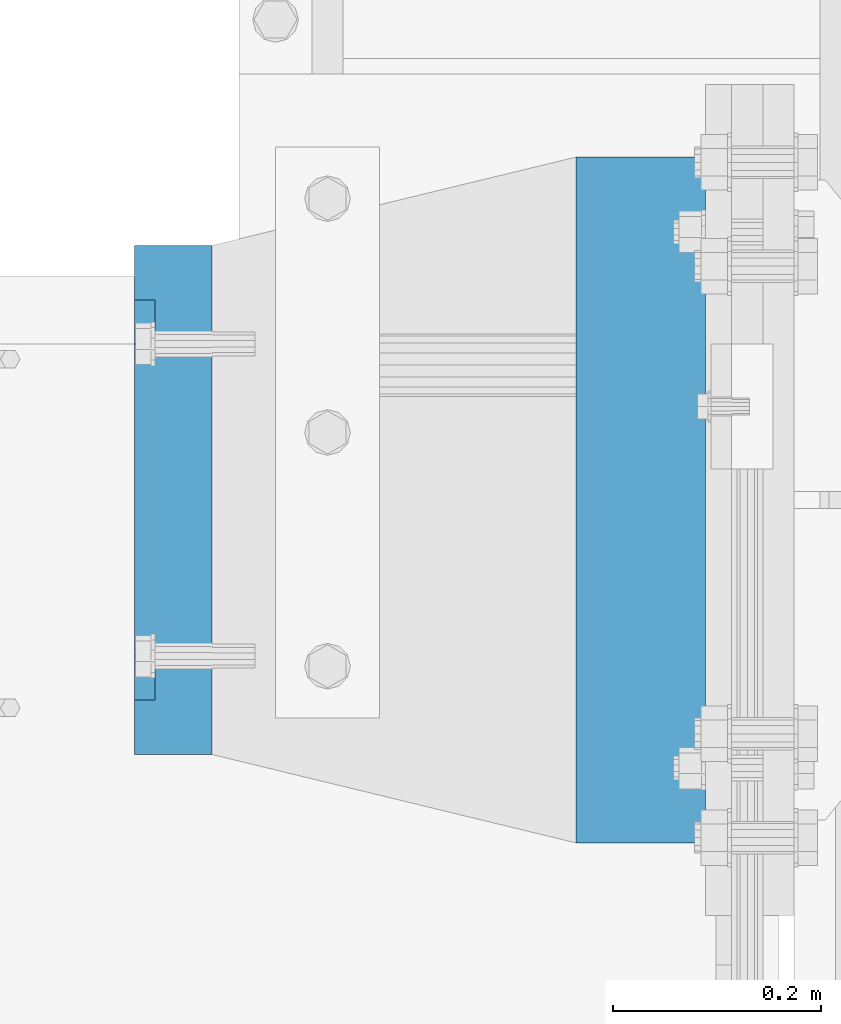
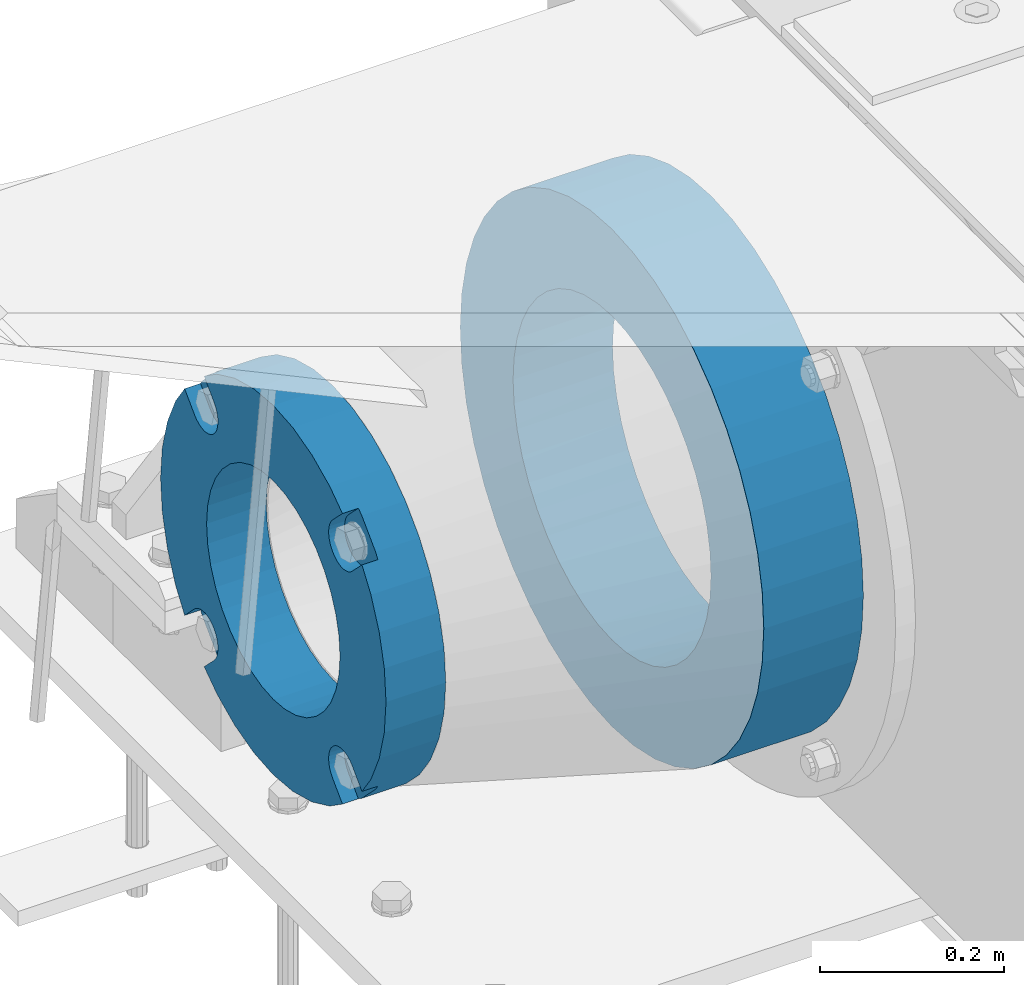
# One storey, part 145 of 242: 2 beams.
"""IFC2X3 building model written with IfcOpenShell, lengths in millimetres."""

from ifc_helpers import new_model, si_unit, frame, origin_with_axes, place, context, subcontext, project, spatial, faceted_brep, material, type_object, element, save


model = new_model("IFC2X3")

# Units and contexts
model_context = context("Model", 3, precision=1e-05, world=origin_with_axes())
body_context = subcontext(model_context, "Body", "Model", "MODEL_VIEW")
ifc_project = project(units=[si_unit("LENGTHUNIT", "METRE", prefix="MILLI"), si_unit("AREAUNIT", "SQUARE_METRE"), si_unit("VOLUMEUNIT", "CUBIC_METRE"), si_unit("MASSUNIT", "GRAM", prefix="KILO"), si_unit("TIMEUNIT", "SECOND"), si_unit("PLANEANGLEUNIT", "RADIAN"), si_unit("SOLIDANGLEUNIT", "STERADIAN"), si_unit("THERMODYNAMICTEMPERATUREUNIT", "DEGREE_CELSIUS"), si_unit("LUMINOUSINTENSITYUNIT", "LUMEN")], contexts=[model_context])

# Site, building, storey
site_placement = place(None, origin_with_axes())
site = spatial("IfcSite", under=ifc_project, at=site_placement, CompositionType="ELEMENT")
building_placement = place(site_placement, origin_with_axes())
building = spatial("IfcBuilding", under=site, at=building_placement, Name="Standard", CompositionType="ELEMENT")
storey_placement = place(building_placement, origin_with_axes())
storey = spatial("IfcBuildingStorey", under=building, at=storey_placement, Name="Undefined", CompositionType="ELEMENT", Elevation=0.0)

# Beams
ifc_material_1 = material(Name="SCN-500-E2")
beam_type_1 = type_object("IfcBeamType", PredefinedType="NOTDEFINED")
beam_1_placement = place(storey_placement, frame((-43000.0, -17999.9999985338, -515.0), z_axis=(0.0, 0.0, 1.0), x_axis=(-1.0, 0.0, 0.0)))
element("IfcBeam", 1, at=beam_1_placement, inside=storey, type_object=beam_type_1, material=ifc_material_1, context=body_context, shape_type="Brep", body=[
    faceted_brep([(75.0, 192.717024793295, -150.290616455868), (75.0, 171.473395903973, -129.046987566545), (55.0, 171.473395903973, -129.046987566545), (55.0, 192.717024793295, -150.290616455868), (75.0, 167.467485558907, -125.685629673471), (55.0, 167.467485558907, -125.685629673471), (75.0, 162.938740320598, -123.070957391042), (55.0, 162.938740320598, -123.070957391042), (75.0, 158.024763821453, -121.282416213469), (55.0, 158.024763821453, -121.282416213469), (75.0, 152.874864750807, -120.374350059389), (55.0, 152.874864750807, -120.374350059389), (75.0, 147.645520185946, -120.374350059389), (55.0, 147.645520185946, -120.374350059389), (75.0, 142.4956211153, -121.282416213469), (55.0, 142.4956211153, -121.282416213469), (75.0, 137.581644616155, -123.070957391042), (55.0, 137.581644616155, -123.070957391042), (75.0, 133.052899377846, -125.685629673471), (55.0, 133.052899377846, -125.685629673471), (75.0, 129.04698903278, -129.046987566545), (55.0, 129.04698903278, -129.046987566545), (75.0, 125.685631139706, -133.05289791161), (55.0, 125.685631139706, -133.05289791161), (75.0, 123.070958857279, -137.58164314992), (55.0, 123.070958857279, -137.58164314992), (75.0, 121.282417679704, -142.495619649066), (55.0, 121.282417679704, -142.495619649066), (75.0, 120.374351525625, -147.645518719712), (55.0, 120.374351525625, -147.645518719712), (75.0, 120.374351525625, -152.874863284571), (55.0, 120.374351525625, -152.874863284571), (75.0, 121.282417679704, -158.024762355217), (55.0, 121.282417679704, -158.024762355217), (75.0, 123.070958857279, -162.938738854362), (55.0, 123.070958857279, -162.938738854362), (75.0, 125.685631139706, -167.467484092673), (55.0, 125.685631139706, -167.467484092673), (75.0, 129.04698903278, -171.473394437738), (55.0, 129.04698903278, -171.473394437738), (55.0, 150.290618180639, -192.717023585596), (75.0, 150.290618180639, -192.717023585596), (55.0, 157.482964373201, -187.68088856415), (55.0, 187.680888564151, -157.482964373202), (75.0, -192.717023585596, 150.290618180643), (75.0, -171.4733929715, 129.046987566545), (55.0, -171.4733929715, 129.046987566545), (55.0, -192.717023585599, 150.290618180643), (75.0, -167.467482626435, 125.685629673472), (55.0, -167.467482626435, 125.685629673472), (75.0, -162.938737388125, 123.070957391042), (55.0, -162.938737388125, 123.070957391042), (75.0, -158.02476088898, 121.282416213469), (55.0, -158.02476088898, 121.282416213469), (75.0, -152.874861818334, 120.374350059389), (55.0, -152.874861818334, 120.374350059389), (75.0, -147.645517253473, 120.374350059389), (55.0, -147.645517253473, 120.374350059389), (75.0, -142.495618182827, 121.282416213469), (55.0, -142.495618182827, 121.282416213469), (75.0, -137.581641683682, 123.070957391042), (55.0, -137.581641683682, 123.070957391042), (75.0, -133.052896445373, 125.685629673472), (55.0, -133.052896445373, 125.685629673472), (75.0, -129.046986100308, 129.046987566545), (55.0, -129.046986100308, 129.046987566545), (75.0, -125.685628207233, 133.05289791161), (55.0, -125.685628207233, 133.05289791161), (75.0, -123.070955924806, 137.58164314992), (55.0, -123.070955924806, 137.58164314992), (75.0, -121.282414747231, 142.495619649066), (55.0, -121.282414747231, 142.495619649066), (75.0, -120.374348593152, 147.645518719712), (55.0, -120.374348593152, 147.645518719712), (75.0, -120.374348593152, 152.874863284571), (55.0, -120.374348593152, 152.874863284571), (75.0, -121.282414747231, 158.024762355217), (55.0, -121.282414747231, 158.024762355217), (75.0, -123.070955924806, 162.938738854362), (55.0, -123.070955924806, 162.938738854362), (75.0, -125.685628207233, 167.467484092673), (55.0, -125.685628207233, 167.467484092673), (75.0, -129.046986100308, 171.473394437738), (55.0, -129.046986100308, 171.473394437738), (55.0, -150.290616455866, 192.717024793295), (75.0, -150.290616455866, 192.717024793295), (75.0, 150.290618180639, 192.717023585597), (75.0, 129.04698903278, 171.473394437739), (55.0, 129.04698903278, 171.473394437739), (55.0, 150.290618180639, 192.717023585598), (75.0, 125.685631139706, 167.467484092674), (55.0, 125.685631139706, 167.467484092674), (75.0, 123.070958857279, 162.938738854364), (55.0, 123.070958857279, 162.938738854364), (75.0, 121.282417679704, 158.024762355218), (55.0, 121.282417679704, 158.024762355218), (75.0, 120.374351525625, 152.874863284572), (55.0, 120.374351525625, 152.874863284572), (75.0, 120.374351525625, 147.645518719713), (55.0, 120.374351525625, 147.645518719713), (75.0, 121.282417679704, 142.495619649067), (55.0, 121.282417679704, 142.495619649067), (75.0, 123.070958857279, 137.581643149922), (55.0, 123.070958857279, 137.581643149922), (75.0, 125.685631139706, 133.052897911611), (55.0, 125.685631139706, 133.052897911611), (75.0, 129.04698903278, 129.046987566546), (55.0, 129.04698903278, 129.046987566546), (75.0, 133.052899377846, 125.685629673473), (55.0, 133.052899377846, 125.685629673473), (75.0, 137.581644616155, 123.070957391043), (55.0, 137.581644616155, 123.070957391043), (75.0, 142.4956211153, 121.282416213471), (55.0, 142.4956211153, 121.282416213471), (75.0, 147.645520185946, 120.37435005939), (55.0, 147.645520185946, 120.37435005939), (75.0, 152.874864750807, 120.37435005939), (55.0, 152.874864750807, 120.37435005939), (75.0, 158.024763821453, 121.282416213471), (55.0, 158.024763821453, 121.282416213471), (75.0, 162.938740320598, 123.070957391043), (55.0, 162.938740320598, 123.070957391043), (75.0, 167.467485558907, 125.685629673473), (55.0, 167.467485558907, 125.685629673473), (75.0, 171.473395903973, 129.046987566546), (55.0, 171.473395903973, 129.046987566546), (55.0, 192.717024793295, 150.290616455869), (75.0, 192.717024793295, 150.290616455868), (0.0, 212.176223927188, -122.5), (0.0, 230.224692092546, -83.7949351147888), (75.0, 230.224692092546, -83.7949351147888), (75.0, 212.176223927188, -122.5), (0.0, 241.277899487992, -42.5438035283978), (75.0, 241.277899487992, -42.5438035283978), (0.0, 245.0, 0.0), (75.0, 245.0, 0.0), (0.0, 241.277899487992, 42.543803528398), (75.0, 241.277899487992, 42.543803528398), (0.0, 230.224692092546, 83.7949351147889), (75.0, 230.224692092546, 83.7949351147889), (0.0, 212.176223927188, 122.5), (75.0, 212.176223927188, 122.5), (0.0, 187.680888564151, 157.482964373202), (55.0, 187.680888564151, 157.482964373202), (0.0, 157.482964373201, 187.68088856415), (55.0, 157.482964373201, 187.68088856415), (0.0, 122.5, 212.176223927187), (75.0, 122.5, 212.176223927187), (0.0, 83.7949351147872, 230.224692092548), (75.0, 83.7949351147872, 230.224692092548), (0.0, 42.5438035283987, 241.277899487991), (75.0, 42.5438035283987, 241.277899487991), (0.0, 0.0, 245.0), (75.0, 0.0, 245.0), (0.0, -42.5438035283987, 241.277899487991), (75.0, -42.5438035283987, 241.277899487991), (0.0, -83.7949351147872, 230.224692092548), (75.0, -83.7949351147872, 230.224692092548), (0.0, -122.5, 212.176223927187), (75.0, -122.5, 212.176223927187), (0.0, -157.482964373201, 187.68088856415), (55.0, -157.482964373201, 187.68088856415), (0.0, -187.680888564151, 157.482964373202), (55.0, -187.680888564151, 157.482964373202), (0.0, -212.176223927188, 122.5), (75.0, -212.176223927188, 122.5), (0.0, -230.224692092546, 83.7949351147888), (75.0, -230.224692092546, 83.7949351147888), (0.0, -241.277899487992, 42.5438035283979), (75.0, -241.277899487992, 42.5438035283979), (0.0, -245.0, 0.0), (75.0, -245.0, 0.0), (0.0, -187.680888564151, -157.482964373202), (0.0, -157.482964373201, -187.68088856415), (55.0, -157.482964373201, -187.68088856415), (55.0, -187.680888564151, -157.482964373202), (0.0, 83.7949351147872, -230.224692092547), (0.0, 122.5, -212.176223927187), (75.0, 122.5, -212.176223927187), (75.0, 83.7949351147872, -230.224692092547), (0.0, 42.5438035283987, -241.277899487991), (75.0, 42.5438035283987, -241.277899487991), (0.0, 0.0, -245.0), (75.0, 0.0, -245.0), (0.0, -42.5438035283987, -241.277899487991), (75.0, -42.5438035283987, -241.277899487991), (0.0, -83.7949351147872, -230.224692092548), (75.0, -83.7949351147872, -230.224692092548), (0.0, -122.5, -212.176223927187), (75.0, -122.5, -212.176223927187), (75.0, -150.290616455863, -192.717024793296), (55.0, -150.290616455863, -192.717024793296), (55.0, -129.046986100308, -171.473394437739), (55.0, -125.685628207233, -167.467484092674), (55.0, -123.070955924806, -162.938738854364), (55.0, -121.282414747231, -158.024762355218), (55.0, -120.374348593152, -152.874863284572), (55.0, -120.374348593152, -147.645518719713), (55.0, -121.282414747231, -142.495619649067), (55.0, -123.070955924806, -137.581643149922), (55.0, -125.685628207233, -133.052897911611), (55.0, -129.046986100308, -129.046987566546), (55.0, -133.052896445373, -125.685629673473), (55.0, -137.581641683682, -123.070957391043), (55.0, -142.495618182827, -121.282416213471), (55.0, -147.645517253473, -120.37435005939), (55.0, -152.874861818334, -120.37435005939), (55.0, -158.02476088898, -121.282416213471), (55.0, -162.938737388125, -123.070957391043), (55.0, -167.467482626435, -125.685629673473), (55.0, -171.4733929715, -129.046987566546), (55.0, -192.717023585596, -150.290618180642), (75.0, -129.046986100308, -171.473394437739), (75.0, -125.685628207233, -167.467484092674), (75.0, -123.070955924806, -162.938738854364), (75.0, -121.282414747231, -158.024762355218), (75.0, -120.374348593152, -152.874863284572), (75.0, -120.374348593152, -147.645518719713), (75.0, -121.282414747231, -142.495619649067), (75.0, -123.070955924806, -137.581643149922), (75.0, -125.685628207233, -133.052897911611), (75.0, -129.046986100308, -129.046987566546), (75.0, -133.052896445373, -125.685629673473), (75.0, -137.581641683682, -123.070957391043), (75.0, -142.495618182827, -121.282416213471), (75.0, -147.645517253473, -120.37435005939), (75.0, -152.874861818334, -120.37435005939), (75.0, -158.02476088898, -121.282416213471), (75.0, -162.938737388125, -123.070957391043), (75.0, -167.467482626435, -125.685629673473), (75.0, -171.4733929715, -129.046987566546), (75.0, -192.717023585596, -150.290618180642), (75.0, -212.176223927188, -122.5), (0.0, -212.176223927188, -122.5), (0.0, -230.224692092546, -83.794935114789), (75.0, -230.224692092546, -83.794935114789), (0.0, -241.277899487992, -42.5438035283979), (75.0, -241.277899487992, -42.5438035283979), (0.0, 187.680888564151, -157.482964373202), (0.0, 157.482964373201, -187.68088856415), (0.0, -142.797124186771, -25.1789857617049), (0.0, -136.255430013956, -49.592920782222), (0.0, -125.573683548744, -72.5), (0.0, -111.076444252252, -93.2042034045483), (0.0, -93.204203404548, -111.076444252252), (0.0, -72.5, -125.573683548744), (0.0, -49.5929207822228, -136.255430013957), (0.0, -25.1789857617041, -142.79712418677), (0.0, 0.0, -145.0), (0.0, 25.1789857617041, -142.79712418677), (0.0, 49.5929207822228, -136.255430013957), (0.0, 72.5, -125.573683548744), (0.0, 93.204203404548, -111.076444252252), (0.0, 111.076444252252, -93.2042034045483), (0.0, 125.573683548744, -72.5), (0.0, 136.255430013956, -49.592920782222), (0.0, 142.797124186771, -25.178985761705), (0.0, 145.0, 0.0), (0.0, 142.797124186771, 25.1789857617048), (0.0, 136.255430013956, 49.5929207822219), (0.0, 125.573683548744, 72.4999999999999), (0.0, 111.076444252252, 93.2042034045482), (0.0, 93.204203404548, 111.076444252252), (0.0, 72.5, 125.573683548744), (0.0, 49.5929207822228, 136.255430013957), (0.0, 25.1789857617041, 142.79712418677), (0.0, 0.0, 145.0), (0.0, -25.1789857617041, 142.79712418677), (0.0, -49.5929207822228, 136.255430013957), (0.0, -72.5, 125.573683548744), (0.0, -93.204203404548, 111.076444252252), (0.0, -111.076444252252, 93.2042034045483), (0.0, -125.573683548744, 72.5000000000001), (0.0, -136.255430013956, 49.5929207822221), (0.0, -142.797124186771, 25.1789857617049), (0.0, -145.0, 0.0), (75.0, -145.0, 0.0), (75.0, -142.797124186771, -25.1789857617049), (75.0, -136.255430013956, -49.592920782222), (75.0, -125.573683548744, -72.5), (75.0, -111.076444252252, -93.2042034045483), (75.0, -93.204203404548, -111.076444252252), (75.0, -72.5, -125.573683548744), (75.0, -49.5929207822228, -136.255430013957), (75.0, -25.1789857617041, -142.79712418677), (75.0, 0.0, -145.0), (75.0, 25.1789857617041, -142.79712418677), (75.0, 49.5929207822228, -136.255430013957), (75.0, 72.5, -125.573683548744), (75.0, 93.204203404548, -111.076444252252), (75.0, 111.076444252252, -93.2042034045483), (75.0, 125.573683548744, -72.5), (75.0, 136.255430013956, -49.592920782222), (75.0, 142.797124186771, -25.178985761705), (75.0, 145.0, 0.0), (75.0, 142.797124186771, 25.1789857617048), (75.0, 136.255430013956, 49.5929207822219), (75.0, 125.573683548744, 72.4999999999999), (75.0, 111.076444252252, 93.2042034045482), (75.0, 93.204203404548, 111.076444252252), (75.0, 72.5, 125.573683548744), (75.0, 49.5929207822228, 136.255430013957), (75.0, 25.1789857617041, 142.79712418677), (75.0, 0.0, 145.0), (75.0, -25.1789857617041, 142.79712418677), (75.0, -49.5929207822228, 136.255430013957), (75.0, -72.5, 125.573683548744), (75.0, -93.204203404548, 111.076444252252), (75.0, -111.076444252252, 93.2042034045483), (75.0, -125.573683548744, 72.5000000000001), (75.0, -136.255430013956, 49.5929207822221), (75.0, -142.797124186771, 25.1789857617049)], [[[0, 1, 2, 3]], [[4, 5, 2, 1]], [[6, 7, 5, 4]], [[8, 9, 7, 6]], [[10, 11, 9, 8]], [[12, 13, 11, 10]], [[14, 15, 13, 12]], [[16, 17, 15, 14]], [[18, 19, 17, 16]], [[20, 21, 19, 18]], [[22, 23, 21, 20]], [[24, 25, 23, 22]], [[26, 27, 25, 24]], [[28, 29, 27, 26]], [[30, 31, 29, 28]], [[32, 33, 31, 30]], [[34, 35, 33, 32]], [[36, 37, 35, 34]], [[38, 39, 37, 36]], [[40, 39, 38, 41]], [[42, 43, 3, 2, 5, 7, 9, 11, 13, 15, 17, 19, 21, 23, 25, 27, 29, 31, 33, 35, 37, 39, 40]], [[44, 45, 46, 47]], [[48, 49, 46, 45]], [[50, 51, 49, 48]], [[52, 53, 51, 50]], [[54, 55, 53, 52]], [[56, 57, 55, 54]], [[58, 59, 57, 56]], [[60, 61, 59, 58]], [[62, 63, 61, 60]], [[64, 65, 63, 62]], [[66, 67, 65, 64]], [[68, 69, 67, 66]], [[70, 71, 69, 68]], [[72, 73, 71, 70]], [[74, 75, 73, 72]], [[76, 77, 75, 74]], [[78, 79, 77, 76]], [[80, 81, 79, 78]], [[82, 83, 81, 80]], [[84, 83, 82, 85]], [[86, 87, 88, 89]], [[90, 91, 88, 87]], [[92, 93, 91, 90]], [[94, 95, 93, 92]], [[96, 97, 95, 94]], [[98, 99, 97, 96]], [[100, 101, 99, 98]], [[102, 103, 101, 100]], [[104, 105, 103, 102]], [[106, 107, 105, 104]], [[108, 109, 107, 106]], [[110, 111, 109, 108]], [[112, 113, 111, 110]], [[114, 115, 113, 112]], [[116, 117, 115, 114]], [[118, 119, 117, 116]], [[120, 121, 119, 118]], [[122, 123, 121, 120]], [[124, 125, 123, 122]], [[126, 125, 124, 127]], [[128, 129, 130, 131]], [[129, 132, 133, 130]], [[132, 134, 135, 133]], [[134, 136, 137, 135]], [[136, 138, 139, 137]], [[138, 140, 141, 139]], [[127, 141, 140, 142, 143, 126]], [[142, 144, 145, 143]], [[89, 88, 91, 93, 95, 97, 99, 101, 103, 105, 107, 109, 111, 113, 115, 117, 119, 121, 123, 125, 126, 143, 145]], [[144, 146, 147, 86, 89, 145]], [[146, 148, 149, 147]], [[148, 150, 151, 149]], [[150, 152, 153, 151]], [[152, 154, 155, 153]], [[154, 156, 157, 155]], [[156, 158, 159, 157]], [[85, 159, 158, 160, 161, 84]], [[160, 162, 163, 161]], [[47, 46, 49, 51, 53, 55, 57, 59, 61, 63, 65, 67, 69, 71, 73, 75, 77, 79, 81, 83, 84, 161, 163]], [[162, 164, 165, 44, 47, 163]], [[164, 166, 167, 165]], [[166, 168, 169, 167]], [[168, 170, 171, 169]], [[172, 173, 174, 175]], [[176, 177, 178, 179]], [[180, 176, 179, 181]], [[182, 180, 181, 183]], [[184, 182, 183, 185]], [[186, 184, 185, 187]], [[188, 186, 187, 189]], [[173, 188, 189, 190, 191, 174]], [[175, 174, 191, 192, 193, 194, 195, 196, 197, 198, 199, 200, 201, 202, 203, 204, 205, 206, 207, 208, 209, 210, 211]], [[190, 212, 192, 191]], [[213, 193, 192, 212]], [[214, 194, 193, 213]], [[215, 195, 194, 214]], [[216, 196, 195, 215]], [[217, 197, 196, 216]], [[218, 198, 197, 217]], [[219, 199, 198, 218]], [[220, 200, 199, 219]], [[221, 201, 200, 220]], [[222, 202, 201, 221]], [[223, 203, 202, 222]], [[224, 204, 203, 223]], [[225, 205, 204, 224]], [[226, 206, 205, 225]], [[227, 207, 206, 226]], [[228, 208, 207, 227]], [[229, 209, 208, 228]], [[230, 210, 209, 229]], [[211, 210, 230, 231]], [[232, 233, 172, 175, 211, 231]], [[234, 233, 232, 235]], [[236, 234, 235, 237]], [[170, 236, 237, 171]], [[168, 166, 164, 162, 160, 158, 156, 154, 152, 150, 148, 146, 144, 142, 140, 138, 136, 134, 132, 129, 128, 238, 239, 177, 176, 180, 182, 184, 186, 188, 173, 172, 233, 234, 236, 170], [240, 241, 242, 243, 244, 245, 246, 247, 248, 249, 250, 251, 252, 253, 254, 255, 256, 257, 258, 259, 260, 261, 262, 263, 264, 265, 266, 267, 268, 269, 270, 271, 272, 273, 274, 275]], [[240, 275, 276, 277]], [[241, 240, 277, 278]], [[242, 241, 278, 279]], [[243, 242, 279, 280]], [[244, 243, 280, 281]], [[245, 244, 281, 282]], [[246, 245, 282, 283]], [[247, 246, 283, 284]], [[248, 247, 284, 285]], [[249, 248, 285, 286]], [[250, 249, 286, 287]], [[251, 250, 287, 288]], [[252, 251, 288, 289]], [[253, 252, 289, 290]], [[254, 253, 290, 291]], [[255, 254, 291, 292]], [[256, 255, 292, 293]], [[257, 256, 293, 294]], [[258, 257, 294, 295]], [[259, 258, 295, 296]], [[260, 259, 296, 297]], [[261, 260, 297, 298]], [[262, 261, 298, 299]], [[263, 262, 299, 300]], [[264, 263, 300, 301]], [[265, 264, 301, 302]], [[266, 265, 302, 303]], [[267, 266, 303, 304]], [[268, 267, 304, 305]], [[269, 268, 305, 306]], [[270, 269, 306, 307]], [[271, 270, 307, 308]], [[272, 271, 308, 309]], [[273, 272, 309, 310]], [[274, 273, 310, 311]], [[275, 274, 311, 276]], [[24, 22, 20, 18, 16, 14, 12, 10, 8, 6, 4, 1, 0, 131, 130, 133, 135, 137, 139, 141, 127, 124, 122, 120, 118, 116, 114, 112, 110, 108, 106, 104, 102, 100, 98, 96, 94, 92, 90, 87, 86, 147, 149, 151, 153, 155, 157, 159, 85, 82, 80, 78, 76, 74, 72, 70, 68, 66, 64, 62, 60, 58, 56, 54, 52, 50, 48, 45, 44, 165, 167, 169, 171, 237, 235, 232, 231, 230, 229, 228, 227, 226, 225, 224, 223, 222, 221, 220, 219, 218, 217, 216, 215, 214, 213, 212, 190, 189, 187, 185, 183, 181, 179, 178, 41, 38, 36, 34, 32, 30, 28, 26], [310, 309, 308, 307, 306, 305, 304, 303, 302, 301, 300, 299, 298, 297, 296, 295, 294, 293, 292, 291, 290, 289, 288, 287, 286, 285, 284, 283, 282, 281, 280, 279, 278, 277, 276, 311]], [[238, 128, 131, 0, 3, 43]], [[239, 238, 43, 42]], [[178, 177, 239, 42, 40, 41]]]),
])
ifc_material_2 = material(Name="STEEL/S355N")
beam_type_2 = type_object("IfcBeamType", PredefinedType="NOTDEFINED")
beam_2_placement = place(storey_placement, frame((-42525.0, -18000.0, -515.0), z_axis=(0.0, 0.0, 1.0), x_axis=(-1.0, 0.0, 0.0)))
element("IfcBeam", 2, at=beam_2_placement, inside=storey, type_object=beam_type_2, material=ifc_material_2, context=body_context, shape_type="Brep", body=[
    faceted_brep([(0.0, -215.0, 0.0), (0.0, -212.811610004399, 30.5976902287563), (125.0, -212.811610004399, 30.5976902287563), (125.0, -215.0, 0.0), (0.0, -206.290989327117, 60.5724997209074), (125.0, -206.290989327117, 60.5724997209074), (0.0, -195.570879001221, 89.3142277954056), (125.0, -195.570879001221, 89.3142277954056), (0.0, -180.869509558703, 116.237775752953), (125.0, -180.869509558703, 116.237775752953), (0.0, -162.486158486165, 140.795057798236), (125.0, -162.486158486165, 140.795057798236), (0.0, -140.795057798237, 162.486158486165), (125.0, -140.795057798237, 162.486158486165), (0.0, -116.237775752954, 180.869509558704), (125.0, -116.237775752954, 180.869509558704), (0.0, -89.3142277954066, 195.570879001222), (125.0, -89.3142277954066, 195.570879001222), (0.0, -60.5724997209072, 206.290989327117), (125.0, -60.5724997209072, 206.290989327117), (0.0, -30.5976902287548, 212.811610004401), (125.0, -30.5976902287548, 212.811610004401), (0.0, 0.0, 215.0), (125.0, 0.0, 215.0), (0.0, 30.5976902287548, 212.811610004401), (125.0, 30.5976902287548, 212.811610004401), (0.0, 60.5724997209072, 206.290989327117), (125.0, 60.5724997209072, 206.290989327117), (0.0, 89.3142277954066, 195.570879001221), (125.0, 89.3142277954066, 195.570879001221), (0.0, 116.237775752954, 180.869509558704), (125.0, 116.237775752954, 180.869509558704), (0.0, 140.795057798237, 162.486158486165), (125.0, 140.795057798237, 162.486158486165), (0.0, 162.486158486165, 140.795057798236), (125.0, 162.486158486165, 140.795057798236), (0.0, 180.869509558703, 116.237775752953), (125.0, 180.869509558703, 116.237775752953), (0.0, 195.570879001221, 89.3142277954056), (125.0, 195.570879001221, 89.3142277954056), (0.0, 206.290989327117, 60.5724997209073), (125.0, 206.290989327117, 60.5724997209073), (0.0, 212.811610004399, 30.5976902287563), (125.0, 212.811610004399, 30.5976902287563), (0.0, 215.0, 0.0), (125.0, 215.0, 0.0), (0.0, 212.811610004399, -30.5976902287563), (125.0, 212.811610004399, -30.5976902287563), (0.0, 206.290989327117, -60.5724997209073), (125.0, 206.290989327117, -60.5724997209073), (0.0, 195.570879001221, -89.3142277954056), (125.0, 195.570879001221, -89.3142277954056), (0.0, 180.869509558703, -116.237775752954), (125.0, 180.869509558703, -116.237775752954), (0.0, 162.486158486165, -140.795057798236), (125.0, 162.486158486165, -140.795057798236), (0.0, 140.795057798237, -162.486158486166), (125.0, 140.795057798237, -162.486158486166), (0.0, 116.237775752954, -180.869509558704), (125.0, 116.237775752954, -180.869509558704), (0.0, 89.3142277954066, -195.570879001221), (125.0, 89.3142277954066, -195.570879001221), (0.0, 60.5724997209072, -206.290989327117), (125.0, 60.5724997209072, -206.290989327117), (0.0, 30.5976902287548, -212.811610004401), (125.0, 30.5976902287548, -212.811610004401), (0.0, 0.0, -215.0), (125.0, 0.0, -215.0), (0.0, -30.5976902287548, -212.811610004401), (125.0, -30.5976902287548, -212.811610004401), (0.0, -60.5724997209072, -206.290989327117), (125.0, -60.5724997209072, -206.290989327117), (0.0, -89.3142277954066, -195.570879001221), (125.0, -89.3142277954066, -195.570879001221), (0.0, -116.237775752954, -180.869509558704), (125.0, -116.237775752954, -180.869509558704), (0.0, -140.795057798237, -162.486158486166), (125.0, -140.795057798237, -162.486158486166), (0.0, -162.486158486165, -140.795057798236), (125.0, -162.486158486165, -140.795057798236), (0.0, -180.869509558703, -116.237775752953), (125.0, -180.869509558703, -116.237775752953), (0.0, -195.570879001221, -89.3142277954056), (125.0, -195.570879001221, -89.3142277954056), (0.0, -206.290989327117, -60.5724997209073), (125.0, -206.290989327117, -60.5724997209073), (0.0, -212.811610004399, -30.5976902287563), (125.0, -212.811610004399, -30.5976902287563), (0.0, -330.0, 0.0), (0.0, -326.641075820709, -46.9638966301842), (125.0, -326.641075820709, -46.9638966301842), (125.0, -330.0, 0.0), (0.0, -316.632681292784, -92.9717437576718), (125.0, -316.632681292784, -92.9717437576718), (0.0, -300.178558466992, -137.086954290623), (125.0, -300.178558466992, -137.086954290623), (0.0, -277.613665834291, -178.411469760347), (125.0, -277.613665834291, -178.411469760347), (0.0, -249.397359536906, -216.104042201944), (125.0, -249.397359536906, -216.104042201944), (0.0, -216.104042201943, -249.397359536905), (125.0, -216.104042201943, -249.397359536905), (0.0, -178.411469760347, -277.61366583429), (125.0, -178.411469760347, -277.61366583429), (0.0, -137.086954290622, -300.178558466991), (125.0, -137.086954290622, -300.178558466991), (0.0, -92.9717437576728, -316.632681292784), (125.0, -92.9717437576728, -316.632681292784), (0.0, -46.9638966301827, -326.641075820708), (125.0, -46.9638966301827, -326.641075820708), (0.0, 0.0, -330.0), (125.0, 0.0, -330.0), (0.0, 46.9638966301827, -326.641075820708), (125.0, 46.9638966301827, -326.641075820708), (0.0, 92.9717437576728, -316.632681292784), (125.0, 92.9717437576728, -316.632681292784), (0.0, 137.086954290622, -300.178558466991), (125.0, 137.086954290622, -300.178558466991), (0.0, 178.411469760347, -277.61366583429), (125.0, 178.411469760347, -277.61366583429), (0.0, 216.104042201943, -249.397359536905), (125.0, 216.104042201943, -249.397359536905), (0.0, 249.397359536906, -216.104042201944), (125.0, 249.397359536906, -216.104042201944), (0.0, 277.613665834291, -178.411469760347), (125.0, 277.613665834291, -178.411469760347), (0.0, 300.178558466992, -137.086954290623), (125.0, 300.178558466992, -137.086954290623), (0.0, 316.632681292784, -92.9717437576717), (125.0, 316.632681292784, -92.9717437576717), (0.0, 326.641075820709, -46.9638966301841), (125.0, 326.641075820709, -46.9638966301841), (0.0, 330.0, 0.0), (125.0, 330.0, 0.0), (0.0, 326.641075820709, 46.9638966301841), (125.0, 326.641075820709, 46.9638966301841), (0.0, 316.632681292784, 92.9717437576718), (125.0, 316.632681292784, 92.9717437576718), (0.0, 300.178558466992, 137.086954290622), (125.0, 300.178558466992, 137.086954290622), (0.0, 277.613665834291, 178.411469760347), (125.0, 277.613665834291, 178.411469760347), (0.0, 249.397359536906, 216.104042201944), (125.0, 249.397359536906, 216.104042201944), (0.0, 216.104042201943, 249.397359536905), (125.0, 216.104042201943, 249.397359536905), (0.0, 178.411469760347, 277.61366583429), (125.0, 178.411469760347, 277.61366583429), (0.0, 137.086954290622, 300.178558466991), (125.0, 137.086954290622, 300.178558466991), (0.0, 92.9717437576728, 316.632681292784), (125.0, 92.9717437576728, 316.632681292784), (0.0, 46.9638966301827, 326.641075820708), (125.0, 46.9638966301827, 326.641075820708), (0.0, 0.0, 330.0), (125.0, 0.0, 330.0), (0.0, -46.9638966301827, 326.641075820708), (125.0, -46.9638966301827, 326.641075820708), (0.0, -92.9717437576728, 316.632681292784), (125.0, -92.9717437576728, 316.632681292784), (0.0, -137.086954290622, 300.178558466991), (125.0, -137.086954290622, 300.178558466991), (0.0, -178.411469760347, 277.61366583429), (125.0, -178.411469760347, 277.61366583429), (0.0, -216.104042201943, 249.397359536905), (125.0, -216.104042201943, 249.397359536905), (0.0, -249.397359536906, 216.104042201944), (125.0, -249.397359536906, 216.104042201944), (0.0, -277.613665834291, 178.411469760347), (125.0, -277.613665834291, 178.411469760347), (0.0, -300.178558466992, 137.086954290623), (125.0, -300.178558466992, 137.086954290623), (0.0, -316.632681292784, 92.9717437576718), (125.0, -316.632681292784, 92.9717437576718), (0.0, -326.641075820709, 46.9638966301841), (125.0, -326.641075820709, 46.9638966301841)], [[[0, 1, 2, 3]], [[1, 4, 5, 2]], [[4, 6, 7, 5]], [[6, 8, 9, 7]], [[8, 10, 11, 9]], [[10, 12, 13, 11]], [[12, 14, 15, 13]], [[14, 16, 17, 15]], [[16, 18, 19, 17]], [[18, 20, 21, 19]], [[20, 22, 23, 21]], [[22, 24, 25, 23]], [[24, 26, 27, 25]], [[26, 28, 29, 27]], [[28, 30, 31, 29]], [[30, 32, 33, 31]], [[32, 34, 35, 33]], [[34, 36, 37, 35]], [[36, 38, 39, 37]], [[38, 40, 41, 39]], [[40, 42, 43, 41]], [[42, 44, 45, 43]], [[44, 46, 47, 45]], [[46, 48, 49, 47]], [[48, 50, 51, 49]], [[50, 52, 53, 51]], [[52, 54, 55, 53]], [[54, 56, 57, 55]], [[56, 58, 59, 57]], [[58, 60, 61, 59]], [[60, 62, 63, 61]], [[62, 64, 65, 63]], [[64, 66, 67, 65]], [[66, 68, 69, 67]], [[68, 70, 71, 69]], [[70, 72, 73, 71]], [[72, 74, 75, 73]], [[74, 76, 77, 75]], [[76, 78, 79, 77]], [[78, 80, 81, 79]], [[80, 82, 83, 81]], [[82, 84, 85, 83]], [[84, 86, 87, 85]], [[86, 0, 3, 87]], [[88, 89, 90, 91]], [[89, 92, 93, 90]], [[92, 94, 95, 93]], [[94, 96, 97, 95]], [[96, 98, 99, 97]], [[98, 100, 101, 99]], [[100, 102, 103, 101]], [[102, 104, 105, 103]], [[104, 106, 107, 105]], [[106, 108, 109, 107]], [[108, 110, 111, 109]], [[110, 112, 113, 111]], [[112, 114, 115, 113]], [[114, 116, 117, 115]], [[116, 118, 119, 117]], [[118, 120, 121, 119]], [[120, 122, 123, 121]], [[122, 124, 125, 123]], [[124, 126, 127, 125]], [[126, 128, 129, 127]], [[128, 130, 131, 129]], [[130, 132, 133, 131]], [[132, 134, 135, 133]], [[134, 136, 137, 135]], [[136, 138, 139, 137]], [[138, 140, 141, 139]], [[140, 142, 143, 141]], [[142, 144, 145, 143]], [[144, 146, 147, 145]], [[146, 148, 149, 147]], [[148, 150, 151, 149]], [[150, 152, 153, 151]], [[152, 154, 155, 153]], [[154, 156, 157, 155]], [[156, 158, 159, 157]], [[158, 160, 161, 159]], [[160, 162, 163, 161]], [[162, 164, 165, 163]], [[164, 166, 167, 165]], [[166, 168, 169, 167]], [[168, 170, 171, 169]], [[170, 172, 173, 171]], [[172, 174, 175, 173]], [[174, 88, 91, 175]], [[93, 95, 97, 99, 101, 103, 105, 107, 109, 111, 113, 115, 117, 119, 121, 123, 125, 127, 129, 131, 133, 135, 137, 139, 141, 143, 145, 147, 149, 151, 153, 155, 157, 159, 161, 163, 165, 167, 169, 171, 173, 175, 91, 90], [5, 7, 9, 11, 13, 15, 17, 19, 21, 23, 25, 27, 29, 31, 33, 35, 37, 39, 41, 43, 45, 47, 49, 51, 53, 55, 57, 59, 61, 63, 65, 67, 69, 71, 73, 75, 77, 79, 81, 83, 85, 87, 3, 2]], [[174, 172, 170, 168, 166, 164, 162, 160, 158, 156, 154, 152, 150, 148, 146, 144, 142, 140, 138, 136, 134, 132, 130, 128, 126, 124, 122, 120, 118, 116, 114, 112, 110, 108, 106, 104, 102, 100, 98, 96, 94, 92, 89, 88], [86, 84, 82, 80, 78, 76, 74, 72, 70, 68, 66, 64, 62, 60, 58, 56, 54, 52, 50, 48, 46, 44, 42, 40, 38, 36, 34, 32, 30, 28, 26, 24, 22, 20, 18, 16, 14, 12, 10, 8, 6, 4, 1, 0]]]),
])

save(model, "model.ifc")
